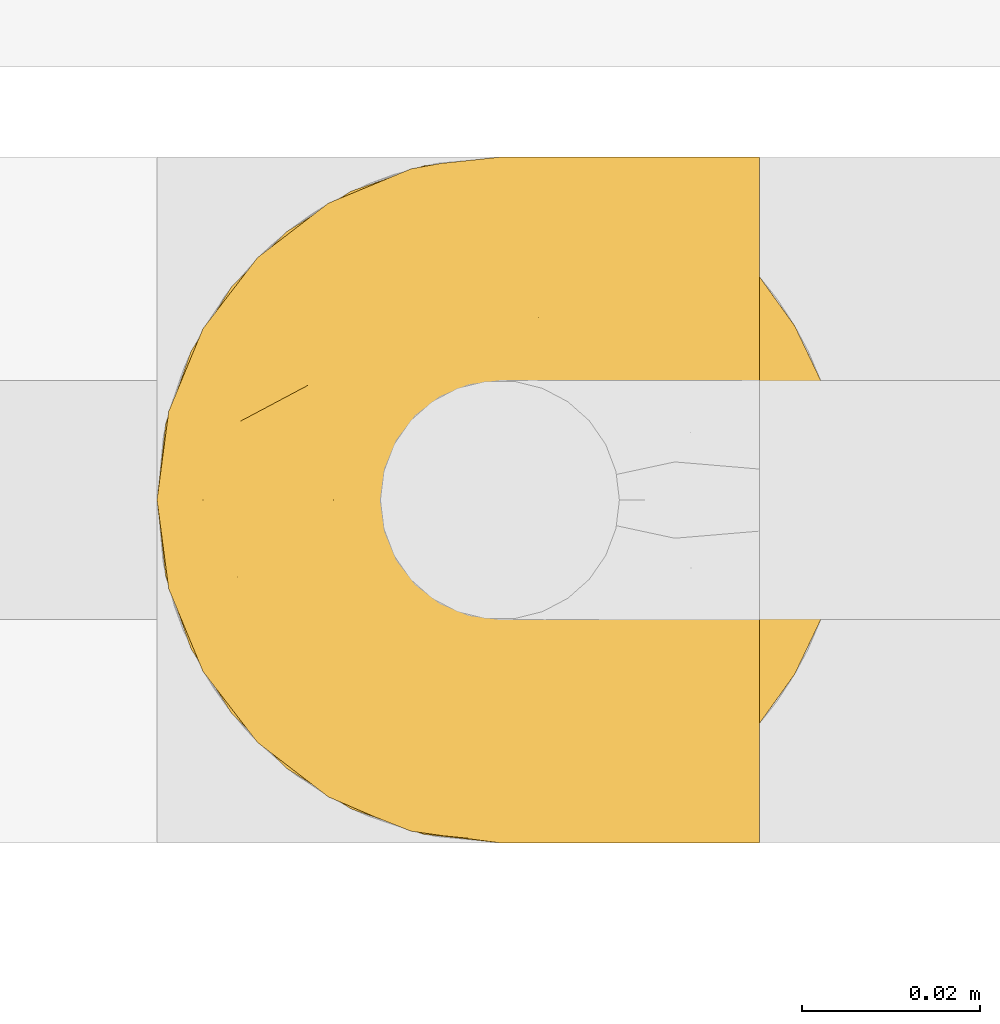
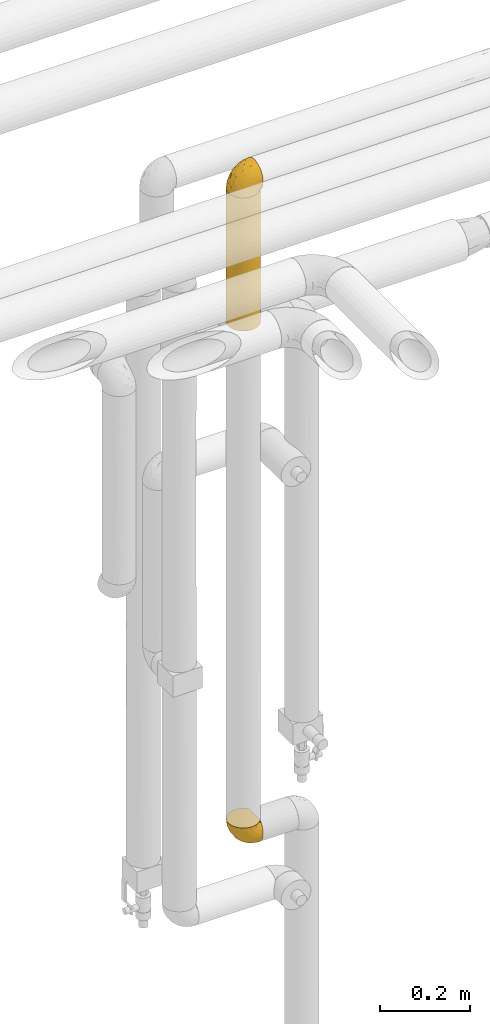
# One storey, part 325 of 827: 3 coverings.
"""IFC2X3 building model written with IfcOpenShell, lengths in millimetres."""

from ifc_helpers import new_model, entity, si_unit, converted_unit, derived_unit, direction, frame, origin, place, context, subcontext, project, spatial, faceted_brep, element, save


model = new_model("IFC2X3")

# Units and contexts
model_context = context("Model", 3, precision=0.01, world=origin(), true_north=direction((6.12303176911189e-17, 1.0)))
body_context = subcontext(model_context, "Body", "Model", "MODEL_VIEW")
ifc_project = project(units=[si_unit("LENGTHUNIT", "METRE", prefix="MILLI"), si_unit("AREAUNIT", "SQUARE_METRE"), si_unit("VOLUMEUNIT", "CUBIC_METRE"), converted_unit("PLANEANGLEUNIT", "DEGREE", entity("IfcRatioMeasure", 0.0174532925199433), si_unit("PLANEANGLEUNIT", "RADIAN"), dimensions=[0, 0, 0, 0, 0, 0, 0]), si_unit("MASSUNIT", "GRAM", prefix="KILO"), derived_unit("MASSDENSITYUNIT", [(si_unit("MASSUNIT", "GRAM", prefix="KILO"), 1), (si_unit("LENGTHUNIT", "METRE"), -3)]), derived_unit("MOMENTOFINERTIAUNIT", [(si_unit("LENGTHUNIT", "METRE"), 4)]), si_unit("TIMEUNIT", "SECOND"), si_unit("FREQUENCYUNIT", "HERTZ"), si_unit("THERMODYNAMICTEMPERATUREUNIT", "DEGREE_CELSIUS"), derived_unit("THERMALTRANSMITTANCEUNIT", [(si_unit("MASSUNIT", "GRAM", prefix="KILO"), 1), (si_unit("THERMODYNAMICTEMPERATUREUNIT", "KELVIN"), -1), (si_unit("TIMEUNIT", "SECOND"), -3)]), derived_unit("VOLUMETRICFLOWRATEUNIT", [(si_unit("LENGTHUNIT", "METRE"), 3), (si_unit("TIMEUNIT", "SECOND"), -1)]), derived_unit("MASSFLOWRATEUNIT", [(si_unit("MASSUNIT", "GRAM", prefix="KILO"), 1), (si_unit("TIMEUNIT", "SECOND"), -1)]), derived_unit("ROTATIONALFREQUENCYUNIT", [(si_unit("TIMEUNIT", "SECOND"), -1)]), si_unit("ELECTRICCURRENTUNIT", "AMPERE"), si_unit("ELECTRICVOLTAGEUNIT", "VOLT"), si_unit("POWERUNIT", "WATT"), si_unit("FORCEUNIT", "NEWTON", prefix="KILO"), si_unit("ILLUMINANCEUNIT", "LUX"), si_unit("LUMINOUSFLUXUNIT", "LUMEN"), si_unit("LUMINOUSINTENSITYUNIT", "CANDELA"), derived_unit("USERDEFINED", [(si_unit("MASSUNIT", "GRAM", prefix="KILO"), -1), (si_unit("LENGTHUNIT", "METRE"), -2), (si_unit("TIMEUNIT", "SECOND"), 3), (si_unit("LUMINOUSFLUXUNIT", "LUMEN"), 1)]), derived_unit("LINEARVELOCITYUNIT", [(si_unit("LENGTHUNIT", "METRE"), 1), (si_unit("TIMEUNIT", "SECOND"), -1)]), si_unit("PRESSUREUNIT", "PASCAL"), derived_unit("USERDEFINED", [(si_unit("LENGTHUNIT", "METRE"), -2), (si_unit("MASSUNIT", "GRAM", prefix="KILO"), 1), (si_unit("TIMEUNIT", "SECOND"), -2)]), derived_unit("LINEARFORCEUNIT", [(si_unit("MASSUNIT", "GRAM", prefix="KILO"), 1), (si_unit("LENGTHUNIT", "METRE"), 1), (si_unit("TIMEUNIT", "SECOND"), -2), (si_unit("LENGTHUNIT", "METRE"), -1)]), derived_unit("PLANARFORCEUNIT", [(si_unit("MASSUNIT", "GRAM", prefix="KILO"), 1), (si_unit("LENGTHUNIT", "METRE"), 1), (si_unit("TIMEUNIT", "SECOND"), -2), (si_unit("LENGTHUNIT", "METRE"), -2)])], contexts=[model_context])

# Site, building, storey
site_placement = place(None, origin())
site = spatial("IfcSite", under=ifc_project, at=site_placement, CompositionType="ELEMENT")
building_placement = place(site_placement, origin())
building = spatial("IfcBuilding", under=site, at=building_placement, CompositionType="ELEMENT")
storey_placement = place(building_placement, frame((0.0, 0.0, 28200.0)))
storey = spatial("IfcBuildingStorey", under=building, at=storey_placement, Name="08", CompositionType="ELEMENT", Elevation=28200.0)

# Coverings
covering_1_placement = place(storey_placement, frame((34650.38, 18294.87, 1189.95)))
element("IfcCovering", 1, at=covering_1_placement, inside=storey, Name=":ADSK_", ObjectType=":ADSK_", PredefinedType="INSULATION", context=body_context, shape_type="Brep", body=[
    faceted_brep([(23.36, 74.68, 69.15), (16.07, 70.1, 69.15), (9.98, 64.01, 69.15), (5.4, 56.72, 69.15), (2.56, 48.6, 69.15), (1.6, 40.05, 69.15), (2.56, 31.49, 69.15), (5.41, 23.36, 69.15), (9.99, 16.07, 69.15), (16.08, 9.98, 69.15), (23.37, 5.4, 69.15), (31.49, 2.56, 69.15), (40.05, 1.6, 69.15), (48.15, 2.46, 69.15), (55.88, 5.01, 69.15), (62.9, 9.13, 69.15), (68.89, 14.62, 69.15), (68.89, 16.82, 69.15), (68.89, 18.56, 69.15), (68.89, 20.52, 69.15), (68.89, 22.49, 69.15), (68.89, 24.46, 69.15), (68.89, 26.42, 69.15), (68.89, 28.39, 69.15), (68.89, 30.36, 69.15), (68.89, 32.55, 69.15), (68.89, 34.75, 69.15), (68.89, 36.94, 69.15), (68.89, 39.13, 69.15), (68.89, 41.33, 69.15), (68.89, 43.52, 69.15), (68.89, 45.72, 69.15), (68.89, 47.91, 69.15), (68.89, 50.11, 69.15), (68.89, 52.3, 69.15), (68.89, 54.49, 69.15), (68.89, 56.69, 69.15), (68.89, 58.88, 69.15), (68.89, 61.08, 69.15), (68.89, 63.27, 69.15), (68.89, 65.47, 69.15), (62.89, 70.97, 69.15), (55.86, 75.09, 69.15), (48.13, 77.64, 69.15), (40.05, 78.5, 69.15), (31.49, 77.53, 69.15), (69.15, 14.62, 68.89), (69.15, 9.12, 62.89), (69.15, 5.0, 55.87), (69.15, 2.46, 48.14), (69.15, 1.6, 40.05), (69.15, 2.91, 30.09), (69.15, 6.75, 20.82), (69.15, 12.86, 12.86), (69.15, 20.82, 6.75), (69.15, 30.09, 2.91), (69.15, 40.05, 1.6), (69.15, 50.0, 2.91), (69.15, 59.27, 6.75), (69.15, 67.23, 12.86), (69.15, 73.34, 20.82), (69.15, 77.19, 30.09), (69.15, 78.5, 40.05), (69.15, 77.63, 48.14), (69.15, 75.09, 55.87), (69.15, 70.97, 62.89), (69.15, 65.47, 68.89), (69.15, 63.27, 68.89), (69.15, 62.29, 68.89), (69.15, 60.7, 68.89), (69.15, 59.11, 68.89), (69.15, 57.52, 68.89), (69.15, 55.93, 68.89), (69.15, 54.34, 68.89), (69.15, 52.76, 68.89), (69.15, 51.17, 68.89), (69.15, 49.58, 68.89), (69.15, 47.99, 68.89), (69.15, 46.4, 68.89), (69.15, 44.81, 68.89), (69.15, 43.22, 68.89), (69.15, 41.63, 68.89), (69.15, 40.05, 68.89), (69.15, 38.46, 68.89), (69.15, 36.87, 68.89), (69.15, 35.28, 68.89), (69.15, 33.69, 68.89), (69.15, 32.1, 68.89), (69.15, 30.51, 68.89), (69.15, 28.92, 68.89), (69.15, 27.33, 68.89), (69.15, 25.37, 68.89), (69.15, 23.4, 68.89), (69.15, 21.21, 68.89), (69.15, 19.01, 68.89), (69.15, 16.82, 68.89), (68.96, 42.32, 68.97), (68.97, 44.02, 68.96), (68.97, 47.13, 68.97), (68.97, 48.74, 68.97), (68.95, 23.57, 68.98), (68.96, 25.13, 68.97), (68.98, 61.34, 68.96), (68.97, 22.02, 68.96), (68.97, 29.72, 68.96), (68.98, 56.73, 68.96), (68.97, 55.14, 68.96), (68.97, 37.66, 68.96), (68.94, 64.12, 69.0), (68.98, 28.13, 68.96), (68.98, 26.62, 68.96), (68.96, 31.46, 68.97), (68.97, 16.16, 68.96), (68.98, 39.16, 68.96), (68.98, 50.37, 68.96), (68.97, 17.69, 68.97), (68.96, 19.17, 68.97), (68.97, 62.78, 68.97), (68.97, 58.35, 68.96), (68.98, 45.53, 68.96), (68.96, 59.91, 68.97), (68.97, 65.47, 68.97), (68.94, 65.47, 69.02), (68.92, 65.47, 69.08), (68.97, 14.62, 68.97), (69.02, 14.62, 68.94), (69.08, 14.62, 68.92), (68.98, 20.59, 68.96), (68.97, 32.99, 68.96), (68.98, 34.48, 68.95), (68.97, 51.91, 68.96), (69.08, 65.47, 68.92), (69.02, 65.47, 68.94), (68.96, 53.48, 68.98), (68.92, 14.62, 69.08), (68.94, 14.62, 69.02), (68.97, 40.77, 68.96), (68.96, 35.97, 68.97), (67.02, 7.84, 61.33), (63.33, 3.53, 53.1), (64.61, 8.32, 63.33), (49.27, 1.6, 49.27), (51.4, 2.19, 55.53), (43.94, 1.6, 54.6), (61.87, 1.6, 41.99), (61.54, 4.57, 57.07), (57.95, 3.96, 57.95), (56.12, 2.28, 51.56), (63.4, 1.6, 41.58), (65.41, 7.69, 61.7), (53.1, 3.53, 63.33), (63.04, 8.32, 65.0), (61.33, 7.84, 67.02), (41.99, 1.6, 61.87), (54.6, 1.6, 43.94), (56.6, 4.34, 61.21), (41.58, 1.6, 63.4), (13.72, 29.63, 33.11), (5.82, 27.34, 52.82), (6.74, 40.05, 43.3), (58.82, 2.39, 33.73), (51.58, 2.43, 36.52), (42.09, 9.07, 24.87), (46.12, 16.64, 14.17), (55.56, 9.54, 18.43), (52.38, 4.52, 28.67), (61.54, 4.52, 26.0), (23.76, 7.49, 49.25), (20.5, 7.49, 59.72), (14.64, 12.85, 55.1), (41.77, 2.35, 44.72), (16.28, 22.66, 34.15), (49.4, 32.9, 5.25), (52.34, 25.33, 6.75), (4.3, 40.05, 55.54), (58.67, 16.64, 10.47), (25.26, 19.99, 25.49), (20.17, 16.37, 35.53), (34.7, 3.26, 48.22), (28.67, 3.75, 58.71), (8.62, 19.58, 57.42), (33.37, 7.5, 34.84), (41.35, 4.04, 36.87), (17.15, 13.94, 45.01), (12.68, 19.58, 44.4), (21.47, 28.21, 23.96), (41.11, 24.75, 11.2), (37.53, 31.42, 10.56), (30.64, 26.2, 16.81), (26.66, 33.36, 17.38), (21.38, 40.05, 21.38), (14.06, 40.05, 32.34), (55.54, 40.05, 4.3), (35.17, 16.14, 20.65), (29.04, 12.85, 29.66), (24.34, 10.47, 39.6), (29.33, 6.49, 42.55), (43.3, 40.05, 6.74), (32.34, 40.05, 14.06), (57.75, 75.57, 26.84), (49.41, 47.37, 5.28), (27.85, 52.91, 18.52), (13.7, 50.46, 33.13), (14.63, 67.23, 55.1), (8.61, 60.5, 57.43), (48.85, 70.55, 20.72), (54.13, 63.45, 11.46), (37.84, 62.61, 17.69), (23.75, 72.6, 49.26), (20.49, 72.6, 59.73), (28.66, 76.34, 58.71), (20.83, 59.34, 29.72), (55.15, 77.76, 35.35), (54.6, 78.5, 43.94), (61.87, 78.5, 41.99), (41.58, 78.5, 63.4), (57.58, 53.16, 4.93), (59.91, 70.55, 17.46), (36.94, 48.88, 10.94), (45.72, 54.76, 8.92), (5.82, 52.74, 52.83), (37.91, 71.93, 29.34), (50.18, 75.79, 30.26), (12.67, 60.5, 44.4), (49.29, 77.86, 39.06), (42.64, 77.64, 43.06), (43.94, 78.5, 54.6), (49.27, 78.5, 49.27), (19.45, 67.23, 42.69), (34.7, 76.82, 48.2), (41.99, 78.5, 61.87), (62.29, 77.8, 33.44), (29.01, 67.23, 29.67), (31.47, 73.2, 38.5), (37.18, 67.66, 23.35), (43.45, 75.99, 34.97), (63.33, 76.57, 53.1), (67.23, 73.21, 59.68), (66.07, 71.93, 62.19), (65.22, 71.07, 64.11), (61.99, 75.09, 57.97), (57.95, 76.13, 57.95), (53.09, 76.57, 63.33), (56.84, 77.69, 51.77), (61.33, 72.26, 67.02), (63.06, 71.77, 64.98), (51.41, 77.9, 55.53), (56.61, 75.75, 61.22)], [[[0, 1, 2, 3, 4, 5, 6, 7, 8, 9, 10, 11, 12, 13, 14, 15, 16, 17, 18, 19, 20, 21, 22, 23, 24, 25, 26, 27, 28, 29, 30, 31, 32, 33, 34, 35, 36, 37, 38, 39, 40, 41, 42, 43, 44, 45]], [[46, 47, 48, 49, 50, 51, 52, 53, 54, 55, 56, 57, 58, 59, 60, 61, 62, 63, 64, 65, 66, 67, 68, 69, 70, 71, 72, 73, 74, 75, 76, 77, 78, 79, 80, 81, 82, 83, 84, 85, 86, 87, 88, 89, 90, 91, 92, 93, 94, 95]], [[96, 97, 30]], [[98, 77, 99]], [[100, 101, 21]], [[69, 68, 102]], [[20, 19, 103]], [[24, 23, 104]], [[20, 103, 100]], [[72, 105, 106]], [[84, 83, 107]], [[89, 88, 104]], [[108, 67, 66]], [[109, 110, 90]], [[111, 25, 24]], [[112, 17, 16]], [[82, 113, 83]], [[109, 23, 22]], [[114, 76, 75]], [[105, 36, 106]], [[104, 111, 24]], [[18, 115, 116]], [[97, 96, 80]], [[67, 108, 117]], [[105, 71, 118]], [[31, 97, 119]], [[102, 120, 69]], [[108, 121, 122, 123, 40]], [[112, 95, 115]], [[17, 115, 18]], [[94, 116, 115]], [[117, 68, 67]], [[38, 117, 39]], [[112, 124, 125, 126, 46]], [[17, 112, 115]], [[70, 120, 118]], [[39, 117, 108]], [[120, 38, 37]], [[120, 37, 118]], [[120, 70, 69]], [[116, 94, 127]], [[128, 86, 129]], [[117, 38, 102]], [[74, 130, 75]], [[99, 33, 32]], [[115, 95, 94]], [[39, 108, 40]], [[108, 66, 131, 132, 121]], [[105, 72, 71]], [[118, 37, 36]], [[71, 70, 118]], [[35, 106, 36]], [[36, 105, 118]], [[35, 133, 106]], [[74, 73, 133]], [[106, 133, 73]], [[99, 114, 33]], [[133, 35, 34]], [[73, 72, 106]], [[95, 112, 46]], [[112, 16, 134, 135, 124]], [[130, 114, 75]], [[99, 76, 114]], [[114, 130, 33]], [[34, 33, 130]], [[78, 77, 98]], [[98, 119, 78]], [[130, 133, 34]], [[133, 130, 74]], [[79, 97, 80]], [[98, 99, 32]], [[98, 32, 31]], [[77, 76, 99]], [[97, 79, 119]], [[136, 96, 29]], [[30, 97, 31]], [[136, 29, 28]], [[81, 80, 96]], [[29, 96, 30]], [[31, 119, 98]], [[119, 79, 78]], [[96, 136, 81]], [[82, 81, 136]], [[113, 107, 83]], [[84, 107, 137]], [[107, 27, 137]], [[113, 28, 107]], [[27, 107, 28]], [[85, 84, 137]], [[137, 27, 26]], [[113, 136, 28]], [[136, 113, 82]], [[109, 89, 104]], [[86, 85, 129]], [[89, 109, 90]], [[111, 87, 128]], [[26, 129, 137]], [[88, 111, 104]], [[25, 111, 128]], [[22, 110, 109]], [[23, 109, 104]], [[110, 91, 90]], [[100, 92, 101]], [[110, 22, 101]], [[91, 110, 101]], [[116, 19, 18]], [[111, 88, 87]], [[127, 103, 19]], [[25, 128, 26]], [[86, 128, 87]], [[128, 129, 26]], [[137, 129, 85]], [[120, 102, 38]], [[117, 102, 68]], [[91, 101, 92]], [[21, 101, 22]], [[93, 92, 103]], [[100, 21, 20]], [[100, 103, 92]], [[127, 93, 103]], [[93, 127, 94]], [[116, 127, 19]], [[126, 138, 47]], [[48, 138, 139]], [[140, 125, 124]], [[141, 142, 143]], [[144, 49, 139]], [[145, 140, 146]], [[48, 139, 49]], [[139, 145, 147]], [[49, 144, 148, 50]], [[126, 125, 149]], [[14, 13, 150]], [[151, 146, 140]], [[149, 140, 145]], [[152, 151, 135]], [[152, 14, 150]], [[16, 15, 134]], [[13, 153, 150]], [[124, 151, 140]], [[141, 147, 142]], [[14, 152, 15]], [[15, 152, 134]], [[47, 46, 126]], [[139, 154, 144]], [[138, 48, 47]], [[125, 140, 149]], [[135, 134, 152]], [[146, 155, 142]], [[145, 146, 147]], [[149, 139, 138]], [[147, 141, 154]], [[147, 146, 142]], [[139, 147, 154]], [[139, 149, 145]], [[149, 138, 126]], [[155, 146, 151]], [[150, 143, 142]], [[152, 155, 151]], [[150, 142, 155]], [[13, 12, 156, 153]], [[153, 143, 150]], [[152, 150, 155]], [[151, 124, 135]], [[157, 158, 159]], [[160, 154, 161]], [[162, 163, 164]], [[165, 166, 160]], [[167, 168, 169]], [[141, 170, 161]], [[156, 12, 11]], [[158, 157, 171]], [[172, 55, 173]], [[158, 6, 174]], [[175, 54, 53]], [[52, 166, 164]], [[52, 164, 53]], [[54, 175, 173]], [[166, 52, 51]], [[176, 177, 171]], [[178, 143, 179]], [[156, 11, 179]], [[8, 7, 180]], [[169, 9, 8]], [[179, 143, 153, 156]], [[179, 11, 10]], [[168, 179, 10]], [[181, 162, 182]], [[179, 167, 178]], [[183, 184, 177]], [[183, 169, 184]], [[176, 171, 185]], [[172, 186, 187]], [[158, 7, 6]], [[159, 158, 174]], [[184, 180, 158]], [[54, 173, 55]], [[180, 169, 8]], [[188, 189, 187]], [[9, 168, 10]], [[186, 188, 187]], [[190, 157, 159, 191]], [[55, 172, 192]], [[176, 193, 194]], [[161, 170, 182]], [[162, 164, 165]], [[175, 164, 163]], [[51, 50, 148]], [[167, 195, 196]], [[178, 182, 170]], [[6, 5, 174]], [[158, 180, 7]], [[169, 180, 184]], [[169, 168, 9]], [[179, 168, 167]], [[182, 162, 165]], [[162, 194, 193]], [[161, 165, 160]], [[195, 181, 196]], [[192, 172, 197]], [[192, 56, 55]], [[189, 190, 198]], [[198, 197, 187]], [[172, 187, 197]], [[185, 189, 188]], [[198, 187, 189]], [[186, 172, 173]], [[173, 163, 186]], [[193, 186, 163]], [[176, 185, 188]], [[185, 157, 190]], [[188, 186, 193]], [[177, 176, 194]], [[188, 193, 176]], [[162, 193, 163]], [[195, 177, 194]], [[171, 177, 184]], [[181, 195, 194]], [[183, 167, 169]], [[162, 181, 194]], [[196, 182, 178]], [[158, 171, 184]], [[171, 157, 185]], [[177, 195, 183]], [[167, 183, 195]], [[182, 196, 181]], [[178, 170, 143]], [[178, 167, 196]], [[164, 175, 53]], [[173, 175, 163]], [[160, 51, 148]], [[164, 166, 165]], [[51, 160, 166]], [[160, 148, 144, 154]], [[141, 161, 154]], [[182, 165, 161]], [[190, 189, 185]], [[143, 170, 141]], [[60, 199, 61]], [[197, 200, 192]], [[201, 190, 202]], [[200, 57, 192]], [[203, 204, 2]], [[205, 206, 207]], [[208, 209, 210]], [[211, 207, 201]], [[212, 213, 214]], [[45, 215, 210]], [[216, 206, 58]], [[45, 44, 215]], [[59, 217, 60]], [[60, 217, 199]], [[0, 45, 210]], [[218, 201, 219]], [[202, 159, 220]], [[205, 221, 222]], [[223, 204, 203]], [[1, 203, 2]], [[57, 200, 216]], [[220, 3, 204]], [[220, 174, 4]], [[1, 0, 209]], [[212, 224, 213]], [[225, 226, 227]], [[228, 223, 203]], [[208, 210, 229]], [[210, 226, 229]], [[3, 220, 4]], [[58, 206, 59]], [[209, 203, 1]], [[202, 220, 223]], [[228, 203, 208]], [[202, 211, 201]], [[3, 2, 204]], [[202, 190, 191, 159]], [[210, 215, 230, 226]], [[199, 212, 231]], [[232, 233, 221]], [[233, 208, 229]], [[207, 206, 219]], [[217, 206, 205]], [[227, 224, 225]], [[233, 232, 228]], [[201, 207, 219]], [[234, 232, 221]], [[218, 219, 200]], [[202, 223, 211]], [[174, 220, 159]], [[174, 5, 4]], [[61, 231, 62]], [[220, 204, 223]], [[210, 209, 0]], [[203, 209, 208]], [[225, 233, 229]], [[224, 227, 213]], [[221, 233, 235]], [[57, 56, 192]], [[198, 218, 197]], [[200, 219, 216]], [[201, 198, 190]], [[197, 218, 200]], [[198, 201, 218]], [[206, 216, 219]], [[58, 57, 216]], [[231, 212, 214]], [[222, 212, 199]], [[228, 211, 223]], [[207, 211, 232]], [[62, 231, 214]], [[199, 231, 61]], [[233, 228, 208]], [[211, 228, 232]], [[222, 221, 235]], [[234, 205, 207]], [[206, 217, 59]], [[199, 217, 205]], [[205, 222, 199]], [[224, 222, 235]], [[222, 224, 212]], [[224, 235, 225]], [[233, 225, 235]], [[226, 225, 229]], [[205, 234, 221]], [[207, 232, 234]], [[63, 214, 236]], [[214, 213, 236]], [[214, 63, 62]], [[237, 236, 238]], [[238, 132, 131]], [[236, 237, 64]], [[239, 240, 241]], [[63, 236, 64]], [[131, 66, 65]], [[237, 131, 65]], [[242, 230, 43]], [[237, 65, 64]], [[239, 121, 132]], [[42, 242, 43]], [[241, 240, 243]], [[41, 123, 244]], [[43, 230, 215, 44]], [[244, 122, 245]], [[227, 246, 243]], [[241, 247, 245]], [[121, 239, 245]], [[41, 40, 123]], [[132, 238, 239]], [[244, 42, 41]], [[131, 237, 238]], [[240, 239, 238]], [[245, 239, 241]], [[247, 241, 246]], [[247, 244, 245]], [[238, 236, 240]], [[243, 236, 213]], [[236, 243, 240]], [[227, 226, 246]], [[243, 213, 227]], [[242, 246, 226]], [[243, 246, 241]], [[246, 242, 247]], [[244, 247, 242]], [[242, 226, 230]], [[42, 244, 242]], [[122, 244, 123]], [[122, 121, 245]]]),
])
covering_2_placement = place(storey_placement, frame((34650.43, 18294.92, 2607.4)))
element("IfcCovering", 2, at=covering_2_placement, inside=storey, Name=":ADSK_", ObjectType=":ADSK_", PredefinedType="INSULATION", context=body_context, shape_type="Brep", body=[
    faceted_brep([(6.74, 20.8, 1.6), (2.9, 30.06, 1.6), (1.6, 40.0, 1.6), (2.9, 49.93, 1.6), (6.74, 59.2, 1.6), (12.84, 67.15, 1.6), (20.8, 73.25, 1.6), (30.06, 77.09, 1.6), (40.0, 78.4, 1.6), (48.16, 77.52, 1.6), (55.94, 74.93, 1.6), (62.99, 70.75, 1.6), (69.0, 65.17, 1.6), (69.0, 14.82, 1.6), (62.99, 9.24, 1.6), (55.94, 5.06, 1.6), (48.16, 2.47, 1.6), (40.0, 1.6, 1.6), (30.06, 2.9, 1.6), (20.8, 6.74, 1.6), (12.84, 12.84, 1.6), (48.2, 77.51, 363.66), (40.0, 78.4, 363.66), (30.06, 77.09, 363.66), (20.8, 73.25, 363.66), (12.84, 67.15, 363.66), (6.74, 59.2, 363.66), (2.9, 49.93, 363.66), (1.6, 40.0, 363.66), (2.9, 30.06, 363.66), (6.74, 20.8, 363.66), (12.84, 12.84, 363.66), (20.8, 6.74, 363.66), (30.06, 2.9, 363.66), (40.0, 1.6, 363.66), (48.2, 2.48, 363.66), (56.01, 5.09, 363.66), (63.08, 9.31, 363.66), (69.1, 14.94, 363.66), (69.1, 65.05, 363.66), (63.08, 70.68, 363.66), (56.01, 74.9, 363.66), (73.07, 59.51, 359.69), (73.01, 59.61, 5.61), (76.0, 53.36, 356.76), (77.79, 46.78, 354.97), (77.78, 46.82, 10.38), (75.97, 53.43, 8.57), (78.4, 40.0, 11.0), (78.4, 40.0, 354.36), (77.79, 33.21, 354.97), (76.0, 26.63, 356.76), (77.78, 33.17, 10.38), (73.07, 20.48, 359.69), (73.01, 20.38, 5.61), (75.97, 26.56, 8.57)], [[[0, 1, 2, 3, 4, 5, 6, 7, 8, 9, 10, 11, 12, 13, 14, 15, 16, 17, 18, 19, 20]], [[21, 22, 23, 24, 25, 26, 27, 28, 29, 30, 31, 32, 33, 34, 35, 36, 37, 38, 39, 40, 41]], [[33, 32, 19, 18]], [[34, 33, 18, 17]], [[20, 19, 32, 31]], [[1, 0, 30, 29]], [[2, 1, 29, 28]], [[31, 30, 0, 20]], [[3, 2, 28, 27]], [[4, 3, 27, 26]], [[26, 25, 5, 4]], [[7, 6, 24, 23]], [[8, 7, 23, 22]], [[25, 24, 6, 5]], [[9, 22, 21]], [[10, 21, 41]], [[11, 41, 40]], [[8, 22, 9]], [[10, 9, 21]], [[41, 11, 10]], [[40, 12, 11]], [[40, 39, 12]], [[39, 42, 43]], [[44, 45, 46]], [[42, 44, 47]], [[43, 42, 47]], [[45, 48, 46]], [[46, 47, 44]], [[48, 45, 49]], [[39, 43, 12]], [[50, 51, 52]], [[53, 38, 54]], [[51, 53, 55]], [[49, 50, 48]], [[48, 50, 52]], [[52, 51, 55]], [[53, 54, 55]], [[38, 13, 54]], [[14, 37, 36]], [[15, 36, 35]], [[16, 35, 34]], [[13, 37, 14]], [[15, 14, 36]], [[35, 16, 15]], [[34, 17, 16]], [[37, 13, 38]], [[12, 43, 47, 46, 48, 52, 55, 54, 13]], [[38, 53, 51, 50, 49, 45, 44, 42, 39]]]),
])
covering_3_placement = place(storey_placement, frame((34650.38, 18294.87, 2969.47)))
element("IfcCovering", 3, at=covering_3_placement, inside=storey, Name=":ADSK_", ObjectType=":ADSK_", PredefinedType="INSULATION", context=body_context, shape_type="Brep", body=[
    faceted_brep([(69.15, 74.68, 47.38), (69.15, 70.1, 54.67), (69.15, 64.01, 60.76), (69.15, 56.72, 65.34), (69.15, 48.6, 68.18), (69.15, 40.05, 69.15), (69.15, 31.49, 68.18), (69.15, 23.36, 65.33), (69.15, 16.07, 60.75), (69.15, 9.98, 54.66), (69.15, 5.4, 47.37), (69.15, 2.56, 39.25), (69.15, 1.6, 30.7), (69.15, 2.46, 22.59), (69.15, 5.01, 14.86), (69.15, 9.13, 7.84), (69.15, 14.62, 1.85), (69.15, 16.82, 1.85), (69.15, 18.56, 1.85), (69.15, 20.52, 1.85), (69.15, 22.49, 1.85), (69.15, 24.46, 1.85), (69.15, 26.42, 1.85), (69.15, 28.39, 1.85), (69.15, 30.36, 1.85), (69.15, 32.55, 1.85), (69.15, 34.75, 1.85), (69.15, 36.94, 1.85), (69.15, 39.13, 1.85), (69.15, 41.33, 1.85), (69.15, 43.52, 1.85), (69.15, 45.72, 1.85), (69.15, 47.91, 1.85), (69.15, 50.11, 1.85), (69.15, 52.3, 1.85), (69.15, 54.49, 1.85), (69.15, 56.69, 1.85), (69.15, 58.88, 1.85), (69.15, 61.08, 1.85), (69.15, 63.27, 1.85), (69.15, 65.47, 1.85), (69.15, 70.97, 7.85), (69.15, 75.09, 14.88), (69.15, 77.64, 22.61), (69.15, 78.5, 30.7), (69.15, 77.53, 39.26), (68.89, 14.62, 1.6), (62.89, 9.12, 1.6), (55.87, 5.0, 1.6), (48.14, 2.46, 1.6), (40.05, 1.6, 1.6), (30.09, 2.91, 1.6), (20.82, 6.75, 1.6), (12.86, 12.86, 1.6), (6.75, 20.82, 1.6), (2.91, 30.09, 1.6), (1.6, 40.05, 1.6), (2.91, 50.0, 1.6), (6.75, 59.27, 1.6), (12.86, 67.23, 1.6), (20.82, 73.34, 1.6), (30.09, 77.19, 1.6), (40.05, 78.5, 1.6), (48.14, 77.63, 1.6), (55.87, 75.09, 1.6), (62.89, 70.97, 1.6), (68.89, 65.47, 1.6), (68.89, 63.27, 1.6), (68.89, 62.29, 1.6), (68.89, 60.7, 1.6), (68.89, 59.11, 1.6), (68.89, 57.52, 1.6), (68.89, 55.93, 1.6), (68.89, 54.34, 1.6), (68.89, 52.76, 1.6), (68.89, 51.17, 1.6), (68.89, 49.58, 1.6), (68.89, 47.99, 1.6), (68.89, 46.4, 1.6), (68.89, 44.81, 1.6), (68.89, 43.22, 1.6), (68.89, 41.63, 1.6), (68.89, 40.05, 1.6), (68.89, 38.46, 1.6), (68.89, 36.87, 1.6), (68.89, 35.28, 1.6), (68.89, 33.69, 1.6), (68.89, 32.1, 1.6), (68.89, 30.51, 1.6), (68.89, 28.92, 1.6), (68.89, 27.33, 1.6), (68.89, 25.37, 1.6), (68.89, 23.4, 1.6), (68.89, 21.21, 1.6), (68.89, 19.01, 1.6), (68.89, 16.82, 1.6), (68.97, 42.32, 1.78), (68.96, 44.02, 1.77), (68.97, 47.13, 1.78), (68.97, 48.74, 1.77), (68.98, 23.57, 1.79), (68.97, 25.13, 1.78), (68.96, 61.34, 1.76), (68.96, 22.02, 1.77), (68.96, 29.72, 1.77), (68.96, 56.73, 1.76), (68.96, 55.14, 1.77), (68.96, 37.66, 1.77), (69.0, 64.12, 1.8), (68.96, 28.13, 1.76), (68.96, 26.62, 1.77), (68.97, 31.46, 1.78), (68.96, 16.16, 1.77), (68.96, 39.16, 1.77), (68.96, 50.37, 1.76), (68.97, 17.69, 1.77), (68.97, 19.17, 1.78), (68.97, 62.78, 1.77), (68.96, 58.35, 1.77), (68.96, 45.53, 1.77), (68.97, 59.91, 1.78), (68.97, 65.47, 1.77), (69.02, 65.47, 1.8), (69.08, 65.47, 1.82), (68.97, 14.62, 1.77), (68.94, 14.62, 1.72), (68.92, 14.62, 1.66), (68.96, 20.59, 1.76), (68.96, 32.99, 1.77), (68.95, 34.48, 1.76), (68.96, 51.91, 1.77), (68.92, 65.47, 1.66), (68.94, 65.47, 1.72), (68.98, 53.48, 1.78), (69.08, 14.62, 1.82), (69.02, 14.62, 1.8), (68.96, 40.77, 1.77), (68.97, 35.97, 1.78), (61.33, 7.84, 3.72), (53.1, 3.53, 7.41), (63.33, 8.32, 6.13), (55.53, 2.19, 19.34), (63.33, 3.53, 17.64), (54.6, 1.6, 26.8), (41.99, 1.6, 8.87), (57.07, 4.57, 9.2), (57.95, 3.96, 12.79), (51.56, 2.28, 14.62), (41.58, 1.6, 7.34), (61.7, 7.69, 5.33), (65.0, 8.32, 7.7), (67.02, 7.84, 9.41), (61.87, 1.6, 28.75), (49.27, 1.6, 21.47), (43.94, 1.6, 16.15), (61.21, 4.34, 14.14), (63.4, 1.6, 29.16), (33.11, 29.63, 57.02), (52.82, 27.34, 64.92), (43.3, 40.05, 64.0), (33.73, 2.39, 11.92), (36.52, 2.43, 19.16), (24.87, 9.07, 28.65), (14.17, 16.64, 24.62), (18.43, 9.54, 15.19), (28.67, 4.52, 18.36), (26.0, 4.52, 9.2), (49.25, 7.49, 46.98), (59.72, 7.49, 50.24), (55.1, 12.85, 56.1), (44.72, 2.35, 28.97), (34.15, 22.66, 54.46), (5.25, 32.9, 21.34), (6.75, 25.33, 18.4), (55.54, 40.05, 66.44), (10.47, 16.64, 12.07), (25.49, 19.99, 45.49), (35.53, 16.37, 50.57), (48.22, 3.26, 36.04), (58.71, 3.75, 42.07), (57.42, 19.58, 62.12), (34.84, 7.5, 37.37), (36.87, 4.04, 29.39), (45.01, 13.94, 53.59), (44.4, 19.58, 58.06), (23.96, 28.21, 49.27), (11.2, 24.75, 29.63), (10.56, 31.42, 33.21), (16.81, 26.2, 40.1), (17.38, 33.36, 44.08), (21.38, 40.05, 49.36), (32.34, 40.05, 56.68), (4.3, 40.05, 15.2), (20.65, 16.14, 35.57), (29.66, 12.85, 41.7), (39.6, 10.47, 46.4), (42.55, 6.49, 41.41), (6.74, 40.05, 27.45), (14.06, 40.05, 38.4), (26.84, 75.57, 12.99), (5.28, 47.37, 21.33), (18.52, 52.91, 42.89), (33.13, 50.46, 57.04), (55.1, 67.23, 56.11), (57.43, 60.5, 62.13), (20.72, 70.55, 21.89), (11.46, 63.45, 16.62), (17.69, 62.61, 32.9), (49.26, 72.6, 46.99), (59.73, 72.6, 50.25), (58.71, 76.34, 42.08), (29.72, 59.34, 49.91), (35.35, 77.76, 15.6), (43.94, 78.5, 16.15), (41.99, 78.5, 8.87), (63.4, 78.5, 29.16), (4.93, 53.16, 13.16), (17.46, 70.55, 10.83), (10.94, 48.88, 33.8), (8.92, 54.76, 25.02), (52.83, 52.74, 64.92), (29.34, 71.93, 32.83), (30.26, 75.79, 20.56), (44.4, 60.5, 58.07), (39.06, 77.86, 21.46), (43.06, 77.64, 28.1), (54.6, 78.5, 26.8), (49.27, 78.5, 21.47), (42.69, 67.23, 51.29), (48.2, 76.82, 36.04), (61.87, 78.5, 28.75), (33.44, 77.8, 8.45), (29.67, 67.23, 41.73), (38.5, 73.2, 39.27), (23.35, 67.66, 33.56), (34.97, 75.99, 27.29), (53.1, 76.57, 7.41), (59.68, 73.21, 3.51), (62.19, 71.93, 4.68), (64.11, 71.07, 5.52), (57.97, 75.09, 8.75), (57.95, 76.13, 12.79), (63.33, 76.57, 17.65), (51.77, 77.69, 13.9), (67.02, 72.26, 9.42), (64.98, 71.77, 7.68), (55.53, 77.9, 19.33), (61.22, 75.75, 14.13)], [[[0, 1, 2, 3, 4, 5, 6, 7, 8, 9, 10, 11, 12, 13, 14, 15, 16, 17, 18, 19, 20, 21, 22, 23, 24, 25, 26, 27, 28, 29, 30, 31, 32, 33, 34, 35, 36, 37, 38, 39, 40, 41, 42, 43, 44, 45]], [[46, 47, 48, 49, 50, 51, 52, 53, 54, 55, 56, 57, 58, 59, 60, 61, 62, 63, 64, 65, 66, 67, 68, 69, 70, 71, 72, 73, 74, 75, 76, 77, 78, 79, 80, 81, 82, 83, 84, 85, 86, 87, 88, 89, 90, 91, 92, 93, 94, 95]], [[96, 97, 30]], [[98, 77, 99]], [[100, 101, 21]], [[69, 68, 102]], [[20, 19, 103]], [[24, 23, 104]], [[20, 103, 100]], [[72, 105, 106]], [[84, 83, 107]], [[89, 88, 104]], [[108, 67, 66]], [[109, 110, 90]], [[111, 25, 24]], [[112, 17, 16]], [[82, 113, 83]], [[109, 23, 22]], [[114, 76, 75]], [[105, 36, 106]], [[104, 111, 24]], [[18, 115, 116]], [[97, 96, 80]], [[67, 108, 117]], [[105, 71, 118]], [[31, 97, 119]], [[102, 120, 69]], [[108, 121, 122, 123, 40]], [[112, 95, 115]], [[17, 115, 18]], [[94, 116, 115]], [[117, 68, 67]], [[38, 117, 39]], [[112, 124, 125, 126, 46]], [[17, 112, 115]], [[70, 120, 118]], [[39, 117, 108]], [[120, 38, 37]], [[120, 37, 118]], [[120, 70, 69]], [[116, 94, 127]], [[128, 86, 129]], [[117, 38, 102]], [[74, 130, 75]], [[99, 33, 32]], [[115, 95, 94]], [[39, 108, 40]], [[108, 66, 131, 132, 121]], [[105, 72, 71]], [[118, 37, 36]], [[71, 70, 118]], [[35, 106, 36]], [[36, 105, 118]], [[35, 133, 106]], [[74, 73, 133]], [[106, 133, 73]], [[99, 114, 33]], [[133, 35, 34]], [[73, 72, 106]], [[95, 112, 46]], [[112, 16, 134, 135, 124]], [[130, 114, 75]], [[99, 76, 114]], [[114, 130, 33]], [[34, 33, 130]], [[78, 77, 98]], [[98, 119, 78]], [[130, 133, 34]], [[133, 130, 74]], [[79, 97, 80]], [[98, 99, 32]], [[98, 32, 31]], [[77, 76, 99]], [[97, 79, 119]], [[136, 96, 29]], [[30, 97, 31]], [[136, 29, 28]], [[81, 80, 96]], [[29, 96, 30]], [[31, 119, 98]], [[119, 79, 78]], [[96, 136, 81]], [[82, 81, 136]], [[113, 107, 83]], [[84, 107, 137]], [[107, 27, 137]], [[113, 28, 107]], [[27, 107, 28]], [[85, 84, 137]], [[137, 27, 26]], [[113, 136, 28]], [[136, 113, 82]], [[109, 89, 104]], [[86, 85, 129]], [[89, 109, 90]], [[111, 87, 128]], [[26, 129, 137]], [[88, 111, 104]], [[25, 111, 128]], [[22, 110, 109]], [[23, 109, 104]], [[110, 91, 90]], [[100, 92, 101]], [[110, 22, 101]], [[91, 110, 101]], [[116, 19, 18]], [[111, 88, 87]], [[127, 103, 19]], [[25, 128, 26]], [[86, 128, 87]], [[128, 129, 26]], [[137, 129, 85]], [[120, 102, 38]], [[117, 102, 68]], [[91, 101, 92]], [[21, 101, 22]], [[93, 92, 103]], [[100, 21, 20]], [[100, 103, 92]], [[127, 93, 103]], [[93, 127, 94]], [[116, 127, 19]], [[126, 138, 47]], [[48, 138, 139]], [[140, 125, 124]], [[141, 142, 143]], [[144, 49, 139]], [[145, 140, 146]], [[48, 139, 49]], [[139, 145, 147]], [[49, 144, 148, 50]], [[126, 125, 149]], [[14, 13, 142]], [[150, 146, 140]], [[149, 140, 145]], [[151, 150, 135]], [[151, 14, 142]], [[16, 15, 134]], [[13, 152, 142]], [[124, 150, 140]], [[141, 143, 153]], [[14, 151, 15]], [[15, 151, 134]], [[47, 46, 126]], [[139, 154, 144]], [[138, 48, 47]], [[125, 140, 149]], [[135, 134, 151]], [[146, 155, 141]], [[145, 146, 147]], [[149, 139, 138]], [[147, 153, 154]], [[147, 146, 141]], [[139, 147, 154]], [[139, 149, 145]], [[149, 138, 126]], [[147, 141, 153]], [[146, 150, 155]], [[151, 155, 150]], [[142, 141, 155]], [[13, 12, 156, 152]], [[152, 143, 142]], [[151, 142, 155]], [[150, 124, 135]], [[157, 158, 159]], [[160, 154, 161]], [[162, 163, 164]], [[165, 166, 160]], [[167, 168, 169]], [[153, 170, 161]], [[156, 12, 11]], [[158, 157, 171]], [[172, 55, 173]], [[158, 6, 174]], [[175, 54, 53]], [[52, 166, 164]], [[52, 164, 53]], [[54, 175, 173]], [[166, 52, 51]], [[176, 177, 171]], [[178, 143, 179]], [[156, 11, 179]], [[8, 7, 180]], [[169, 9, 8]], [[179, 143, 152, 156]], [[179, 11, 10]], [[168, 179, 10]], [[181, 162, 182]], [[179, 167, 178]], [[183, 184, 177]], [[183, 169, 184]], [[176, 171, 185]], [[172, 186, 187]], [[158, 7, 6]], [[159, 158, 174]], [[184, 180, 158]], [[54, 173, 55]], [[180, 169, 8]], [[188, 189, 187]], [[9, 168, 10]], [[186, 188, 187]], [[190, 157, 159, 191]], [[55, 172, 192]], [[176, 193, 194]], [[161, 170, 182]], [[162, 164, 165]], [[175, 164, 163]], [[51, 50, 148]], [[167, 195, 196]], [[178, 182, 170]], [[6, 5, 174]], [[158, 180, 7]], [[169, 180, 184]], [[169, 168, 9]], [[179, 168, 167]], [[182, 162, 165]], [[162, 194, 193]], [[161, 165, 160]], [[195, 181, 196]], [[192, 172, 197]], [[192, 56, 55]], [[189, 190, 198]], [[198, 197, 187]], [[172, 187, 197]], [[185, 189, 188]], [[198, 187, 189]], [[186, 172, 173]], [[173, 163, 186]], [[193, 186, 163]], [[176, 185, 188]], [[185, 157, 190]], [[188, 186, 193]], [[177, 176, 194]], [[188, 193, 176]], [[162, 193, 163]], [[195, 177, 194]], [[171, 177, 184]], [[181, 195, 194]], [[183, 167, 169]], [[162, 181, 194]], [[196, 182, 178]], [[158, 171, 184]], [[171, 157, 185]], [[177, 195, 183]], [[167, 183, 195]], [[182, 196, 181]], [[178, 170, 143]], [[178, 167, 196]], [[164, 175, 53]], [[173, 175, 163]], [[160, 51, 148]], [[164, 166, 165]], [[51, 160, 166]], [[160, 148, 144, 154]], [[153, 161, 154]], [[182, 165, 161]], [[190, 189, 185]], [[143, 170, 153]], [[60, 199, 61]], [[197, 200, 192]], [[201, 190, 202]], [[200, 57, 192]], [[203, 204, 2]], [[205, 206, 207]], [[208, 209, 210]], [[211, 207, 201]], [[212, 213, 214]], [[45, 215, 210]], [[216, 206, 58]], [[45, 44, 215]], [[59, 217, 60]], [[60, 217, 199]], [[0, 45, 210]], [[218, 201, 219]], [[202, 159, 220]], [[205, 221, 222]], [[223, 204, 203]], [[1, 203, 2]], [[57, 200, 216]], [[220, 3, 204]], [[220, 174, 4]], [[1, 0, 209]], [[212, 224, 213]], [[225, 226, 227]], [[228, 223, 203]], [[208, 210, 229]], [[210, 226, 229]], [[3, 220, 4]], [[58, 206, 59]], [[209, 203, 1]], [[202, 220, 223]], [[228, 203, 208]], [[202, 211, 201]], [[3, 2, 204]], [[202, 190, 191, 159]], [[210, 215, 230, 226]], [[199, 212, 231]], [[232, 233, 221]], [[233, 208, 229]], [[207, 206, 219]], [[217, 206, 205]], [[227, 224, 225]], [[233, 232, 228]], [[201, 207, 219]], [[234, 232, 221]], [[218, 219, 200]], [[202, 223, 211]], [[174, 220, 159]], [[174, 5, 4]], [[61, 231, 62]], [[220, 204, 223]], [[210, 209, 0]], [[203, 209, 208]], [[225, 233, 229]], [[224, 227, 213]], [[221, 233, 235]], [[57, 56, 192]], [[198, 218, 197]], [[200, 219, 216]], [[201, 198, 190]], [[197, 218, 200]], [[198, 201, 218]], [[206, 216, 219]], [[58, 57, 216]], [[231, 212, 214]], [[222, 212, 199]], [[228, 211, 223]], [[207, 211, 232]], [[62, 231, 214]], [[199, 231, 61]], [[233, 228, 208]], [[211, 228, 232]], [[222, 221, 235]], [[234, 205, 207]], [[206, 217, 59]], [[199, 217, 205]], [[205, 222, 199]], [[224, 222, 235]], [[222, 224, 212]], [[224, 235, 225]], [[233, 225, 235]], [[226, 225, 229]], [[205, 234, 221]], [[207, 232, 234]], [[63, 214, 236]], [[214, 213, 236]], [[214, 63, 62]], [[237, 236, 238]], [[238, 132, 131]], [[236, 237, 64]], [[239, 240, 241]], [[63, 236, 64]], [[131, 66, 65]], [[237, 131, 65]], [[242, 230, 43]], [[237, 65, 64]], [[239, 121, 132]], [[42, 242, 43]], [[241, 240, 243]], [[41, 123, 244]], [[43, 230, 215, 44]], [[244, 122, 245]], [[227, 246, 243]], [[245, 241, 247]], [[121, 239, 245]], [[41, 40, 123]], [[132, 238, 239]], [[244, 42, 41]], [[131, 237, 238]], [[240, 239, 238]], [[245, 239, 241]], [[247, 241, 246]], [[247, 244, 245]], [[238, 236, 240]], [[243, 236, 213]], [[236, 243, 240]], [[246, 241, 243]], [[243, 213, 227]], [[226, 242, 246]], [[227, 226, 246]], [[246, 242, 247]], [[244, 247, 242]], [[242, 226, 230]], [[42, 244, 242]], [[122, 244, 123]], [[122, 121, 245]]]),
])

save(model, "model.ifc")
